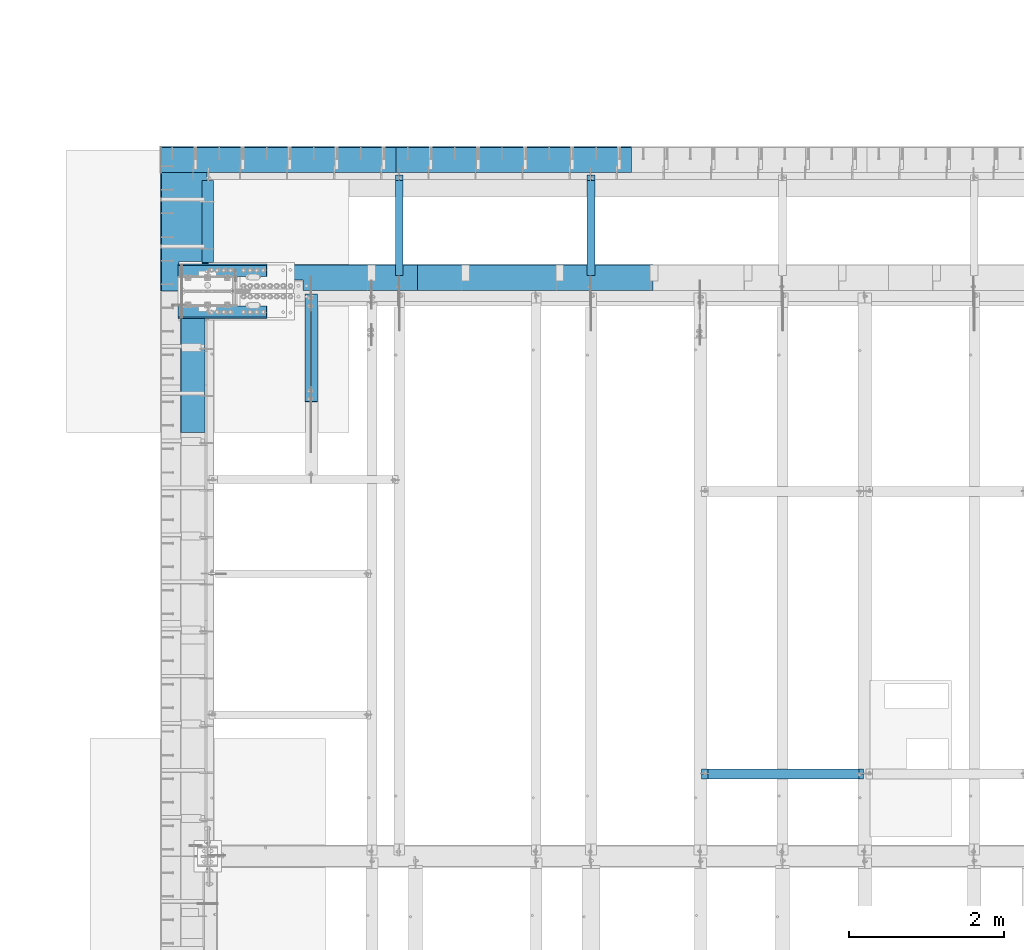
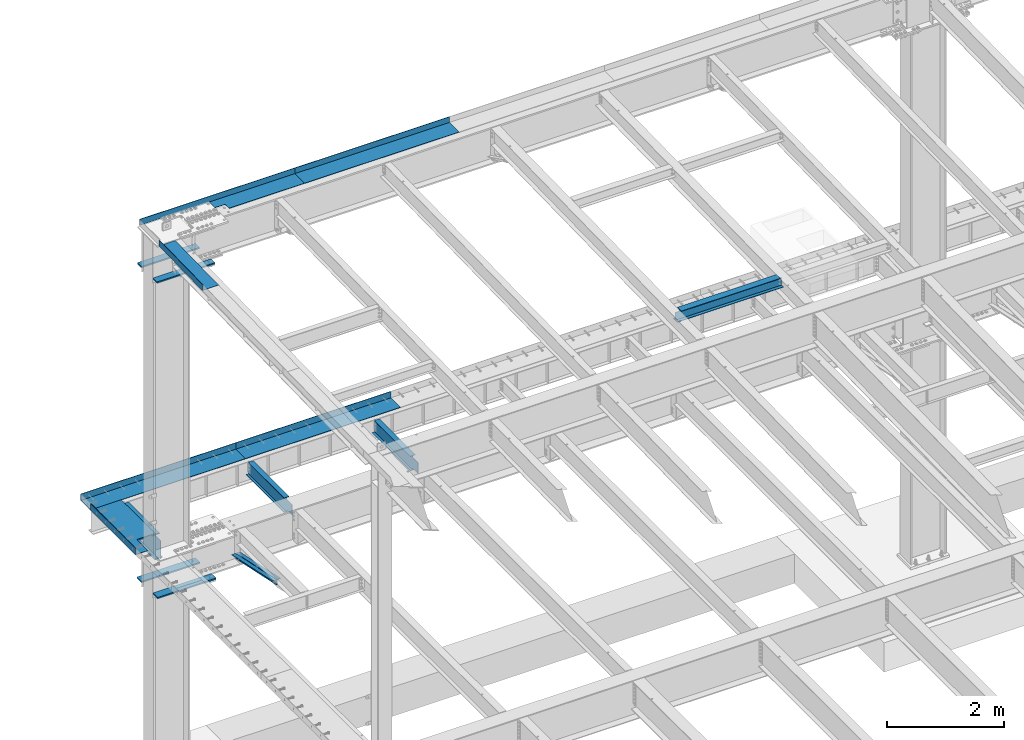
# One storey, part 1125 of 1763: 16 beams, 9 elements without a shape of their own.
"""IFC2X3 building model written with IfcOpenShell, lengths in millimetres."""

from ifc_helpers import new_model, si_unit, frame, origin_with_axes, place, context, subcontext, project, spatial, faceted_brep, material, type_object, element, aggregate, save


model = new_model("IFC2X3")

# Units and contexts
model_context = context("Model", 3, precision=1e-05, world=origin_with_axes())
body_context = subcontext(model_context, "Body", "Model", "MODEL_VIEW")
ifc_project = project(units=[si_unit("LENGTHUNIT", "METRE", prefix="MILLI"), si_unit("AREAUNIT", "SQUARE_METRE"), si_unit("VOLUMEUNIT", "CUBIC_METRE"), si_unit("MASSUNIT", "GRAM", prefix="KILO"), si_unit("TIMEUNIT", "SECOND"), si_unit("PLANEANGLEUNIT", "RADIAN"), si_unit("SOLIDANGLEUNIT", "STERADIAN"), si_unit("THERMODYNAMICTEMPERATUREUNIT", "DEGREE_CELSIUS"), si_unit("LUMINOUSINTENSITYUNIT", "LUMEN")], contexts=[model_context])

# Site, building, storey
site_placement = place(None, origin_with_axes())
site = spatial("IfcSite", under=ifc_project, at=site_placement, CompositionType="ELEMENT")
building_placement = place(site_placement, origin_with_axes())
building = spatial("IfcBuilding", under=site, at=building_placement, Name="Undefined", CompositionType="ELEMENT")
storey_placement = place(building_placement, origin_with_axes())
storey = spatial("IfcBuildingStorey", under=building, at=storey_placement, Name="Undefined", CompositionType="ELEMENT", Elevation=0.0)

# Assembly, beam
assembly_1_placement = place(storey_placement, origin_with_axes())
assembly_1 = element("IfcElementAssembly", 1, at=assembly_1_placement, inside=storey, Name="BEAM", AssemblyPlace="NOTDEFINED", PredefinedType="RIGID_FRAME")
ifc_material_1 = material(Name="STEEL/A992")
beam_type_1 = type_object("IfcBeamType", Name="W8X18", PredefinedType="NOTDEFINED")
beam_1_placement = place(assembly_1_placement, frame((-80902.2926318412, 45872.003125, 11514.3236170495), z_axis=(0.0, 0.0, 1.0), x_axis=(1.0, 0.0, 0.0)))
beam_1 = element("IfcBeam", 2, at=beam_1_placement, type_object=beam_type_1, material=ifc_material_1, Name="BEAM", ObjectType="W8X18", context=body_context, shape_type="Brep", body=[
    faceted_brep([(1960.42688668017, -3.17500000386644, 68.5472454981009), (1960.42688668019, 3.1749999961321, 68.5472454981009), (1959.56590192083, 3.17499999613938, 69.8358002505338), (1959.56590177228, -3.17500000385917, 69.8358004728379), (1964.54706314833, -3.17500000387372, 65.7942315976234), (1964.54706314833, 3.17499999612482, 65.7942315976234), (1969.40714266637, -3.175000003881, 64.8275016750358), (1969.40714266639, 3.17499999611755, 64.8275016750358), (2015.44464294919, -3.17500000397558, 64.8275016750358), (2015.44464276504, 3.17499999602296, 64.8275016750358), (1958.83938981475, -3.17500000385917, 70.3212402430472), (1958.83938963059, 3.17499999613938, 70.3212402430472), (1956.08637573011, 3.17499999613938, 74.4414167112009), (1956.08637591427, -3.17500000385917, 74.4414167112009), (1955.11964580753, 3.17499999614665, 79.3014962292473), (1955.11964599168, -3.17500000385917, 79.3014962292473), (3.17499685616349, 3.17499999998836, 95.25), (3.17499501466227, 66.6749999999884, 95.25), (1955.11964396603, 66.6749999961467, 95.25), (1955.11964580753, 3.17499999614665, 95.25), (3.17499888181919, -66.6750000000102, 103.1875), (3.17499888181919, -66.6750000000102, 95.25), (1955.11964783318, -66.6750000038592, 95.25), (1955.11964783318, -66.6750000038592, 103.1875), (3.17499501466227, 66.6749999999884, 103.1875), (1955.11964396603, 66.6749999961467, 103.1875), (1955.11964599168, -3.17500000385917, 95.25), (3.17499704031798, -3.17500000001019, 95.25), (3.17499685616349, 3.17499999998836, 79.3014961863064), (3.17499704031798, -3.17500000001019, 79.3014961863064), (2.20826693357958, 3.17499999998836, 74.44141666826), (2.20826711773407, -3.17500000001019, 74.44141666826), (-0.544746966901585, 3.17499999999563, 70.3212402001063), (-0.544746782747097, -3.17500000000291, 70.3212402001063), (-1.27125895427889, 3.17499999999563, 69.83580040995), (-1.27125910282484, -3.17500000000291, 69.8358001876459), (-2.13224382305634, 3.17499999999563, 68.5472454937626), (-2.13224382307089, -3.17500000000291, 68.5472454937626), (-6.25242029121728, 3.17500000001019, 65.7942315932851), (-6.25242029121728, -3.17499999998836, 65.7942315932851), (-11.1124998092564, 3.17500000001746, 64.8275016706975), (-11.112499809271, -3.17499999998108, 64.8275016706975), (-79.3750000920845, 3.17500000014843, 64.8275016706975), (-79.37499990793, -3.17499999985012, 64.8275016706975), (-79.3750000920845, 3.17500000014843, -95.25), (-79.3750019335857, 66.6750000001484, -95.25), (-79.3750019335857, 66.6750000001484, -103.1875), (-79.3749980664288, -66.6749999998501, -103.1875), (-79.3749980664288, -66.6749999998501, -95.25), (-79.37499990793, -3.17499999985012, -95.25), (2015.44464276504, 3.17499999602296, -95.25), (2015.44464092355, 66.674999996023, -95.25), (2015.44464092355, 66.674999996023, -103.1875), (2015.4446447907, -66.6750000039756, -103.1875), (2015.4446447907, -66.6750000039756, -95.25), (2015.44464294919, -3.17500000397558, -95.25)], [[[0, 1, 2, 3]], [[4, 5, 1, 0]], [[6, 7, 5, 4]], [[8, 9, 7, 6]], [[10, 11, 12, 13]], [[13, 12, 14, 15]], [[16, 17, 18, 19]], [[20, 21, 22, 23]], [[24, 20, 23, 25]], [[17, 24, 25, 18]], [[23, 22, 26, 15, 14, 19, 18, 25]], [[21, 27, 26, 22]], [[20, 24, 17, 16, 28, 29, 27, 21]], [[29, 28, 30, 31]], [[31, 30, 32, 33]], [[33, 32, 34, 35]], [[35, 34, 36, 37]], [[37, 36, 38, 39]], [[39, 38, 40, 41]], [[41, 40, 42, 43]], [[44, 45, 46, 47, 48, 49, 43, 42]], [[45, 44, 50, 51]], [[46, 45, 51, 52]], [[47, 46, 52, 53]], [[48, 47, 53, 54]], [[49, 48, 54, 55]], [[4, 0, 3, 10, 13, 15, 26, 27, 29, 31, 33, 35, 37, 39, 41, 43, 49, 55, 8, 6]], [[11, 10, 3, 2]], [[50, 44, 42, 40, 38, 36, 34, 32, 30, 28, 16, 19, 14, 12, 11, 2, 1, 5, 7, 9]], [[55, 54, 53, 52, 51, 50, 9, 8]]]),
])
aggregate(assembly_1, [beam_1])

# Assembly, beams
assembly_2_placement = place(storey_placement, origin_with_axes())
assembly_2 = element("IfcElementAssembly", 3, at=assembly_2_placement, inside=storey, Name="COLUMN", AssemblyPlace="NOTDEFINED", PredefinedType="RIGID_FRAME")
ifc_material_2 = material(Name="STEEL/A572-50")
beam_type_2 = type_object("IfcBeamType", PredefinedType="NOTDEFINED")
beam_2_placement = place(assembly_2_placement, frame((-87758.0247736983, 51857.2750002128, 10983.9124917654), z_axis=(0.0, 1.0, 0.0), x_axis=(1.0, 0.0, 0.0)))
beam_2 = element("IfcBeam", 4, at=beam_2_placement, type_object=beam_type_2, material=ifc_material_2, Name="PLATE", context=body_context, shape_type="Brep", body=[
    faceted_brep([(0.0, 14.2875000000004, -69.8499999999985), (0.0, 14.2875000000004, 69.8499999999985), (1143.0, 14.2875000000004, 69.8499999999985), (1143.0, 14.2875000000004, -69.8499999999985), (0.0, -14.2875000000004, 69.8499999999985), (1143.0, -14.2875000000004, 69.8499999999985), (0.0, -14.2875000000004, -69.8499999999985), (1143.0, -14.2875000000004, -69.8499999999985)], [[[0, 1, 2, 3]], [[1, 4, 5, 2]], [[4, 6, 7, 5]], [[6, 0, 3, 7]], [[5, 7, 3, 2]], [[6, 4, 1, 0]]]),
])
beam_3_placement = place(assembly_2_placement, frame((-87758.0247736983, 52384.3250002128, 10983.9124917654), z_axis=(0.0, 1.0, 0.0), x_axis=(1.0, 0.0, 0.0)))
beam_3 = element("IfcBeam", 5, at=beam_3_placement, type_object=beam_type_2, material=ifc_material_2, Name="PLATE", context=body_context, shape_type="Brep", body=[
    faceted_brep([(0.0, 14.2875000000004, -69.8499999999985), (0.0, 14.2875000000004, 69.8499999999985), (1143.0, 14.2875000000004, 69.8499999999985), (1143.0, 14.2875000000004, -69.8499999999985), (0.0, -14.2875000000004, 69.8499999999985), (1143.0, -14.2875000000004, 69.8499999999985), (0.0, -14.2875000000004, -69.8499999999985), (1143.0, -14.2875000000004, -69.8499999999985)], [[[0, 1, 2, 3]], [[1, 4, 5, 2]], [[4, 6, 7, 5]], [[6, 0, 3, 7]], [[5, 7, 3, 2]], [[6, 4, 1, 0]]]),
])
beam_type_3 = type_object("IfcBeamType", PredefinedType="NOTDEFINED")
beam_4_placement = place(assembly_2_placement, frame((-87758.0247736983, 51847.75, 4433.8875), z_axis=(0.0, 1.0, 0.0), x_axis=(1.0, 0.0, 0.0)))
beam_4 = element("IfcBeam", 6, at=beam_4_placement, type_object=beam_type_3, material=ifc_material_2, Name="PLATE", context=body_context, shape_type="Brep", body=[
    faceted_brep([(0.0, 14.2875000000004, -79.375), (0.0, 14.2875000000004, 79.375), (1152.52499999999, 14.2875000000004, 79.375), (1152.52499999999, 14.2875000000004, -79.375), (0.0, -14.2875000000004, 79.375), (1152.52499999999, -14.2875000000004, 79.375), (0.0, -14.2875000000004, -79.375), (1152.52499999999, -14.2875000000004, -79.375)], [[[0, 1, 2, 3]], [[1, 4, 5, 2]], [[4, 6, 7, 5]], [[6, 0, 3, 7]], [[5, 7, 3, 2]], [[6, 4, 1, 0]]]),
])
beam_5_placement = place(assembly_2_placement, frame((-87758.0247736983, 52393.85, 4433.8875), z_axis=(0.0, 1.0, 0.0), x_axis=(1.0, 0.0, 0.0)))
beam_5 = element("IfcBeam", 7, at=beam_5_placement, type_object=beam_type_3, material=ifc_material_2, Name="PLATE", context=body_context, shape_type="Brep", body=[
    faceted_brep([(0.0, 14.2875000000004, -79.375), (0.0, 14.2875000000004, 79.375), (1152.52499999999, 14.2875000000004, 79.375), (1152.52499999999, 14.2875000000004, -79.375), (0.0, -14.2875000000004, 79.375), (1152.52499999999, -14.2875000000004, 79.375), (0.0, -14.2875000000004, -79.375), (1152.52499999999, -14.2875000000004, -79.375)], [[[0, 1, 2, 3]], [[1, 4, 5, 2]], [[4, 6, 7, 5]], [[6, 0, 3, 7]], [[5, 7, 3, 2]], [[6, 4, 1, 0]]]),
])
aggregate(assembly_2, [beam_2, beam_3, beam_4, beam_5])

assembly_3_placement = place(storey_placement, origin_with_axes())
assembly_3 = element("IfcElementAssembly", 8, at=assembly_3_placement, inside=storey, Name="ANGLE BRACE", AssemblyPlace="NOTDEFINED", PredefinedType="RIGID_FRAME")
ifc_material_3 = material(Name="STEEL/A36")
beam_type_4 = type_object("IfcBeamType", Name="L4X3X5/16", PredefinedType="NOTDEFINED")
beam_6_placement = place(assembly_3_placement, frame((-86080.0372736984, 50680.4564530846, 4820.75267554856), z_axis=(0.0, -0.2072236520035, -0.978293595016513), x_axis=(0.0, 0.978293600950479, -0.20722362398951)))
beam_6 = element("IfcBeam", 9, at=beam_6_placement, type_object=beam_type_4, material=ifc_material_3, Name="ANGLE BRACE", ObjectType="L4X3X5/16", context=body_context, shape_type="Brep", body=[
    faceted_brep([(1.45519152283669e-10, 38.0999999999985, -50.7999999999993), (1.45519152283669e-10, 38.0999999999985, 50.7999999999993), (1427.42255777739, 38.0999999999985, 50.7999999995518), (1427.42255777754, 38.0999999999985, -50.8000000004868), (-7.27595761418343e-11, 30.1624999999985, 50.8000000000211), (1427.42255777739, 30.1624999999985, 50.7999999995518), (7.27595761418343e-11, 30.1624999999985, -42.8625000000175), (1427.42255777754, 30.1624999999985, -42.8625000004868), (7.27595761418343e-11, -38.0999999999985, -42.8625000000175), (1427.42255777754, -38.0999999999985, -42.8625000004868), (-1.23691279441118e-10, -38.1000000000022, -50.7999999999993), (1427.42255777754, -38.0999999999985, -50.8000000004868)], [[[0, 1, 2, 3]], [[1, 4, 5, 2]], [[4, 6, 7, 5]], [[6, 8, 9, 7]], [[8, 10, 11, 9]], [[10, 0, 3, 11]], [[5, 7, 9, 11, 3, 2]], [[10, 8, 6, 4, 1, 0]]]),
])
beam_7_placement = place(assembly_3_placement, frame((-85994.3122736983, 52076.9355387112, 4524.94833056974), z_axis=(0.0, -0.2072236520035, -0.978293595016513), x_axis=(0.0, -0.978293595016513, 0.207223652003498)))
beam_7 = element("IfcBeam", 10, at=beam_7_placement, type_object=beam_type_4, material=ifc_material_3, Name="ANGLE BRACE", ObjectType="L4X3X5/16", context=body_context, shape_type="Brep", body=[
    faceted_brep([(1.45519152283669e-10, 38.0999999999985, -50.7999999999993), (1.45519152283669e-10, 38.0999999999985, 50.7999999999993), (1427.46422513096, 38.0999999999985, 50.7999999991189), (1427.46422513096, 38.0999999999985, -50.8000000008396), (-7.27595761418343e-11, 30.1624999999985, 50.8000000000211), (1427.46422513096, 30.1624999999985, 50.7999999991189), (7.27595761418343e-11, 30.1624999999985, -42.8625000000175), (1427.46422513096, 30.1624999999985, -42.8625000008433), (7.27595761418343e-11, -38.0999999999985, -42.8625000000175), (1427.46422513096, -38.0999999999985, -42.8625000008433), (-1.23691279441118e-10, -38.1000000000022, -50.7999999999993), (1427.46422513096, -38.0999999999985, -50.8000000008396)], [[[0, 1, 2, 3]], [[1, 4, 5, 2]], [[4, 6, 7, 5]], [[6, 8, 9, 7]], [[8, 10, 11, 9]], [[10, 0, 3, 11]], [[5, 7, 9, 11, 3, 2]], [[10, 8, 6, 4, 1, 0]]]),
])
aggregate(assembly_3, [beam_6, beam_7])

# Assembly, beam
assembly_4_placement = place(storey_placement, origin_with_axes())
assembly_4 = element("IfcElementAssembly", 11, at=assembly_4_placement, inside=storey, Name="BEAM", AssemblyPlace="NOTDEFINED", PredefinedType="RIGID_FRAME")
beam_type_5 = type_object("IfcBeamType", PredefinedType="NOTDEFINED")
beam_8_placement = place(assembly_4_placement, frame((-87381.7872736983, 52890.7375, 5199.0625), z_axis=(0.0, -1.0, 0.0), x_axis=(-1.0, 0.0, 0.0)))
beam_8 = element("IfcBeam", 12, at=beam_8_placement, type_object=beam_type_5, material=ifc_material_3, Name="BENT_PLATE", context=body_context, shape_type="Brep", body=[
    faceted_brep([(363.537500000006, -4.76249999999982, 385.762499999997), (363.537500000006, 4.76249999999982, 385.762499999997), (0.0, 4.76249999999982, 385.762499999997), (0.0, -4.76249999999982, 385.762499999997), (363.537500000006, -4.76249999999982, 766.762499999983), (363.537500000006, 4.76249999999982, 766.762499999997), (593.725000000006, -4.76249999999982, -766.762499999997), (0.0, -4.76249999999982, -766.762499999997), (0.0, 4.76249999999982, -766.762499999997), (603.25, 4.76249999999982, -766.762499999997), (603.25, -134.937496948242, -766.762499999997), (593.725000000006, -134.937496948242, -766.762499999997), (603.25, 4.76249999999982, 766.762499999997), (603.25, -134.937496948242, 766.762499999997), (593.725000000006, -134.937496948242, 766.762499999997), (593.725000000006, -4.76249999999982, 766.762499999997)], [[[0, 1, 2, 3]], [[4, 5, 1, 0]], [[6, 7, 8, 9, 10, 11]], [[9, 12, 13, 10]], [[14, 11, 10, 13]], [[15, 6, 11, 14]], [[3, 7, 6, 15, 4, 0]], [[8, 7, 3, 2]], [[12, 9, 8, 2, 1, 5]], [[15, 14, 13, 12, 5, 4]]]),
])

# Assembly, beams
assembly_5_placement = place(storey_placement, origin_with_axes())
assembly_5 = element("IfcElementAssembly", 13, at=assembly_5_placement, inside=storey, Name="BEAM", AssemblyPlace="NOTDEFINED", PredefinedType="RIGID_FRAME")
beam_type_6 = type_object("IfcBeamType", PredefinedType="NOTDEFINED")
beam_9_placement = place(assembly_5_placement, frame((-83135.2247736984, 52133.5000002128, 11752.2624917654), z_axis=(-1.0, 0.0, 0.0), x_axis=(0.0, 1.0, 0.0)))
beam_9 = element("IfcBeam", 14, at=beam_9_placement, type_object=beam_type_6, material=ifc_material_3, Name="BENT_PLATE", context=body_context, shape_type="Brep", body=[
    faceted_brep([(0.0, -4.76249999999982, -1524.0), (0.0, -4.76249999999982, 1524.0), (0.0, 4.76249999999982, 1524.0), (0.0, 4.76249999999982, -1524.0), (336.549987792969, 4.76250000000073, 1524.0), (336.549987792969, 4.76250000000073, -1524.0), (327.024987792975, -4.76250000000073, -1524.0), (327.024987792967, -4.76250000000073, 1524.00000000001), (336.549987792969, -122.237499999999, 1524.0), (336.549987792969, -122.237499999999, -1524.0), (327.024987792975, -122.237499999999, 1524.0), (327.024987792975, -122.237499999999, -1524.0)], [[[0, 1, 2, 3]], [[3, 2, 4, 5]], [[1, 0, 6, 7]], [[5, 4, 8, 9]], [[4, 2, 1, 7, 10, 8]], [[7, 6, 11, 10]], [[6, 0, 3, 5, 9, 11]], [[10, 11, 9, 8]]]),
])
beam_type_7 = type_object("IfcBeamType", PredefinedType="NOTDEFINED")
beam_10_placement = place(assembly_5_placement, frame((-86183.2247736984, 52133.5000002128, 11752.2624917654), z_axis=(-1.0, 0.0, 0.0), x_axis=(0.0, 1.0, 0.0)))
beam_10 = element("IfcBeam", 15, at=beam_10_placement, type_object=beam_type_7, material=ifc_material_3, Name="BENT_PLATE", context=body_context, shape_type="Brep", body=[
    faceted_brep([(133.35001525878, -4.76250000000073, -44.4498535156163), (133.35001525878, 4.76250000000073, -44.4498535156163), (0.0, 4.76250000000073, -44.4498535156163), (0.0, -4.76250000000073, -44.4498535156163), (133.35001525878, -4.76250000000073, 158.750097656259), (133.35001525878, 4.76250000000073, 158.750097656259), (327.024987792975, -4.76250000000073, 158.750097656259), (327.024987793302, 4.76250000000073, 158.750097656259), (327.024987792967, -4.76250000000073, 1524.00000000001), (327.024987792967, 4.76250000000073, 1524.0), (327.024987792975, -4.76250000000073, -1524.0), (0.0, -4.76249999999982, -1524.0), (0.0, 4.76249999999982, -1524.0), (336.549987792969, 4.76250000000073, -1524.0), (336.549987792969, -122.237499999999, -1524.0), (327.024987792975, -122.237499999999, -1524.0), (336.549987792969, 4.76250000000073, 1524.0), (336.549987792969, -122.237499999999, 1524.0), (327.024987792975, -122.237499999999, 1524.0), (327.024987792975, -99.5375007629373, 1524.0)], [[[0, 1, 2, 3]], [[4, 5, 1, 0]], [[6, 7, 5, 4]], [[8, 9, 7, 6]], [[10, 11, 12, 13, 14, 15]], [[13, 16, 17, 14]], [[18, 15, 14, 17]], [[19, 8, 6, 10, 15, 18]], [[0, 3, 11, 10, 6, 4]], [[12, 11, 3, 2]], [[16, 13, 12, 2, 1, 5, 7, 9]], [[19, 18, 17, 16, 9, 8]]]),
])
aggregate(assembly_5, [beam_10, beam_9])

# Assembly, beam
assembly_6_placement = place(storey_placement, origin_with_axes())
assembly_6 = element("IfcElementAssembly", 16, at=assembly_6_placement, inside=storey, Name="BEAM", AssemblyPlace="NOTDEFINED", PredefinedType="RIGID_FRAME")
beam_type_8 = type_object("IfcBeamType", PredefinedType="NOTDEFINED")
beam_11_placement = place(assembly_6_placement, frame((-87407.1872736983, 51034.067612332, 11728.1915532733), z_axis=(0.0, -0.999786037781472, -0.0206852279954809), x_axis=(-1.0, 0.0, 0.0)))
beam_11 = element("IfcBeam", 17, at=beam_11_placement, type_object=beam_type_8, material=ifc_material_3, Name="BENT_PLATE", context=body_context, shape_type="Brep", body=[
    faceted_brep([(0.0, -3.174999999801, -740.118000002141), (-1.45519152283669e-11, -3.17500000019572, 740.118000002127), (0.0, 3.17499999979918, 740.118000002134), (1.45519152283669e-11, 3.17500000019027, -740.118000002134), (317.500000000087, 3.17499999899519, 740.118000002127), (317.500000000146, 3.17499999938627, -740.118000002134), (311.15000000014, -3.17500000059226, -740.118000002134), (311.150000000081, -3.17500000098516, 740.118000002127), (317.500000000116, -123.824997298514, 740.118000002112), (317.500000000116, -123.824997298163, -740.118000002156), (311.150000000111, -123.824997298514, 740.118000002112), (311.150000000111, -123.824997298163, -740.118000002156)], [[[0, 1, 2, 3]], [[3, 2, 4, 5]], [[1, 0, 6, 7]], [[5, 4, 8, 9]], [[4, 2, 1, 7, 10, 8]], [[7, 6, 11, 10]], [[6, 0, 3, 5, 9, 11]], [[10, 11, 9, 8]]]),
])
aggregate(assembly_6, [beam_11])

# Assembly, beams
assembly_7_placement = place(storey_placement, origin_with_axes())
assembly_7 = element("IfcElementAssembly", 18, at=assembly_7_placement, inside=storey, Name="BEAM", AssemblyPlace="NOTDEFINED", PredefinedType="RIGID_FRAME")
beam_type_9 = type_object("IfcBeamType", PredefinedType="NOTDEFINED")
beam_12_placement = place(assembly_7_placement, frame((-83413.0372736984, 53657.5, 5199.0625), z_axis=(1.0, 0.0, 0.0), x_axis=(0.0, 1.0, 0.0)))
beam_12 = element("IfcBeam", 19, at=beam_12_placement, type_object=beam_type_9, material=ifc_material_3, Name="BENT PLATE", context=body_context, shape_type="Brep", body=[
    faceted_brep([(0.0, -4.76249999999982, -1524.0), (0.0, -4.76249999999982, 1524.0), (0.0, 4.76249999999982, 1524.0), (0.0, 4.76249999999982, -1524.0), (327.024987792967, 4.76250000000073, 1524.0), (327.025018310553, 4.76249999999982, -1524.0), (336.550018310547, -4.76249999999982, -1524.0), (336.550018310547, -4.76249999999982, 1524.0), (327.025018310553, 134.937496948242, 1524.0), (327.025018310553, 134.937496948242, -1524.0), (336.550018310547, 134.937496948242, 1524.0), (336.550018310547, 134.937496948242, -1524.0)], [[[0, 1, 2, 3]], [[3, 2, 4, 5]], [[1, 0, 6, 7]], [[5, 4, 8, 9]], [[4, 2, 1, 7, 10, 8]], [[7, 6, 11, 10]], [[6, 0, 3, 5, 9, 11]], [[10, 11, 9, 8]]]),
])
beam_13_placement = place(assembly_7_placement, frame((-86461.0372736984, 53657.5, 5199.0625), z_axis=(1.0, 0.0, 0.0), x_axis=(0.0, 1.0, 0.0)))
beam_13 = element("IfcBeam", 20, at=beam_13_placement, type_object=beam_type_9, material=ifc_material_3, Name="BENT PLATE", context=body_context, shape_type="Brep", body=[
    faceted_brep([(0.0, -4.76249999999982, -1524.0), (0.0, -4.76249999999982, 1524.0), (0.0, 4.76249999999982, 1524.0), (0.0, 4.76249999999982, -1524.0), (327.024987792967, 4.76250000000073, 1524.0), (327.025018310553, 4.76249999999982, -1524.0), (336.550018310547, -4.76249999999982, -1524.0), (336.550018310547, -4.76249999999982, 1524.0), (327.025018310553, 134.937496948242, 1524.0), (327.025018310553, 134.937496948242, -1524.0), (336.550018310547, 134.937496948242, 1524.0), (336.550018310547, 134.937496948242, -1524.0)], [[[0, 1, 2, 3]], [[3, 2, 4, 5]], [[1, 0, 6, 7]], [[5, 4, 8, 9]], [[4, 2, 1, 7, 10, 8]], [[7, 6, 11, 10]], [[6, 0, 3, 5, 9, 11]], [[10, 11, 9, 8]]]),
])
aggregate(assembly_7, [beam_12, beam_13])

# Assembly, beam
assembly_8_placement = place(storey_placement, origin_with_axes())
assembly_8 = element("IfcElementAssembly", 21, at=assembly_8_placement, inside=storey, Name="BEAM", AssemblyPlace="NOTDEFINED", PredefinedType="RIGID_FRAME")
beam_type_10 = type_object("IfcBeamType", Name="W12X16", PredefinedType="NOTDEFINED")
beam_14_placement = place(assembly_8_placement, frame((-82413.9706070317, 52120.8, 5041.9), z_axis=(0.0, 0.0, 1.0), x_axis=(0.0, 1.0, 0.0)))
beam_14 = element("IfcBeam", 22, at=beam_14_placement, type_object=beam_type_10, material=ifc_material_1, Name="BEAM", ObjectType="W12X16", context=body_context, shape_type="Brep", body=[
    faceted_brep([(20.6374999999971, -3.17500000000291, -114.3), (20.6374999999971, 3.17500000000291, -114.3), (192.087500190733, 3.17500000000291, -114.3), (192.087500190733, -3.17500000000291, -114.3), (196.94757970878, 3.17500000000291, -115.266729922588), (196.94757970878, -3.17500000000291, -115.266729922588), (201.067756176933, 3.17500000000291, -118.019743823066), (201.067756176933, -3.17500000000291, -118.019743823066), (203.820770077407, 3.17500000000291, -122.13992029122), (203.820770077407, -3.17500000000291, -122.13992029122), (204.787499999999, -3.17500000000291, -126.999999809265), (204.787499999999, 3.17500000000291, -126.999999809265), (204.787499999999, 3.17500000000291, -146.05), (204.787499999999, 50.8000000000029, -146.05), (204.787499999999, 50.8000000000029, -152.4), (204.787499999999, -50.8000000000029, -152.4), (204.787499999999, -50.8000000000029, -146.05), (204.787499999999, -3.17500000000291, -146.05), (1431.13125000001, 50.8000000000029, 146.05), (1431.13125000001, 3.17500000000291, 146.05), (204.787499999999, 3.17500000000291, 146.05), (204.787499999999, 50.8000000000029, 146.05), (192.087500190733, -3.17500000000291, 114.3), (192.087500190733, 3.17500000000291, 114.3), (20.6374999999971, 3.17500000000291, 114.3), (20.6374999999971, -3.17500000000291, 114.3), (196.94757970878, -3.17500000000291, 115.266729922588), (196.94757970878, 3.17500000000291, 115.266729922588), (201.067756176933, -3.17500000000291, 118.019743823066), (201.067756176933, 3.17500000000291, 118.019743823066), (203.820770077407, -3.17500000000291, 122.13992029122), (203.820770077407, 3.17500000000291, 122.13992029122), (204.787499999999, -3.17500000000291, 126.999999809265), (204.787499999999, 3.17500000000291, 126.999999809265), (1431.13125000001, -50.8000000000029, 152.4), (1431.13125000001, 50.8000000000029, 152.4), (204.787499999999, 50.8000000000029, 152.4), (204.787499999999, -50.8000000000029, 152.4), (1431.13125000001, -50.8000000000029, 146.05), (204.787499999999, -50.8000000000029, 146.05), (1431.13125000001, -3.17500000000291, 146.05), (204.787499999999, -3.17500000000291, 146.05), (1431.13125000001, -3.17500000000291, 139.440001487732), (1431.13125000001, 3.17500000000291, 139.440001487732), (1432.0979799226, -3.17500000000291, 134.579921969686), (1432.0979799226, 3.17500000000291, 134.579921969686), (1434.85099382307, -3.17500000000291, 130.459745501533), (1434.85099382307, 3.17500000000291, 130.459745501533), (1438.97117029122, -3.17500000000291, 127.706731601054), (1438.97117029122, 3.17500000000291, 127.706731601054), (1443.83124980927, -3.17500000000291, 126.740001678467), (1443.83124980927, 3.17500000000291, 126.740001678467), (1507.33125, -3.17500000000291, 126.740001678467), (1507.33125, 3.17500000000291, 126.740001678467), (1507.33125, -3.17500000000291, -146.05), (1507.33125, -50.8000000000029, -146.05), (1507.33125, -50.8000000000029, -152.4), (1507.33125, 50.8000000000029, -152.4), (1507.33125, 50.8000000000029, -146.05), (1507.33125, 3.17500000000291, -146.05)], [[[0, 1, 2, 3]], [[3, 2, 4, 5]], [[5, 4, 6, 7]], [[7, 6, 8, 9]], [[10, 11, 12, 13, 14, 15, 16, 17]], [[9, 8, 11, 10]], [[18, 19, 20, 21]], [[22, 23, 24, 25]], [[26, 27, 23, 22]], [[28, 29, 27, 26]], [[30, 31, 29, 28]], [[32, 33, 31, 30]], [[34, 35, 36, 37]], [[38, 34, 37, 39]], [[40, 38, 39, 41]], [[37, 36, 21, 20, 33, 32, 41, 39]], [[35, 18, 21, 36]], [[34, 38, 40, 42, 43, 19, 18, 35]], [[44, 45, 43, 42]], [[46, 47, 45, 44]], [[48, 49, 47, 46]], [[50, 51, 49, 48]], [[52, 53, 51, 50]], [[54, 55, 56, 57, 58, 59, 53, 52]], [[55, 54, 17, 16]], [[56, 55, 16, 15]], [[57, 56, 15, 14]], [[58, 57, 14, 13]], [[59, 58, 13, 12]], [[6, 4, 2, 1, 24, 23, 27, 29, 31, 33, 20, 19, 43, 45, 47, 49, 51, 53, 59, 12, 11, 8]], [[25, 24, 1, 0]], [[54, 52, 50, 48, 46, 44, 42, 40, 41, 32, 30, 28, 26, 22, 25, 0, 3, 5, 7, 9, 10, 17]]]),
])
aggregate(assembly_8, [beam_14])

assembly_9_placement = place(storey_placement, origin_with_axes())
assembly_9 = element("IfcElementAssembly", 23, at=assembly_9_placement, inside=storey, Name="BEAM", AssemblyPlace="NOTDEFINED", PredefinedType="RIGID_FRAME")
beam_15_placement = place(assembly_9_placement, frame((-84894.703940365, 52120.8, 5041.9), z_axis=(0.0, 0.0, 1.0), x_axis=(0.0, 1.0, 0.0)))
beam_15 = element("IfcBeam", 24, at=beam_15_placement, type_object=beam_type_10, material=ifc_material_1, Name="BEAM", ObjectType="W12X16", context=body_context, shape_type="Brep", body=[
    faceted_brep([(20.6374999999971, -3.17500000000291, -114.3), (20.6374999999971, 3.17500000000291, -114.3), (192.087500190733, 3.17500000000291, -114.3), (192.087500190733, -3.17500000000291, -114.3), (196.94757970878, 3.17500000000291, -115.266729922588), (196.94757970878, -3.17500000000291, -115.266729922588), (201.067756176933, 3.17500000000291, -118.019743823066), (201.067756176933, -3.17500000000291, -118.019743823066), (203.820770077407, 3.17500000000291, -122.13992029122), (203.820770077407, -3.17500000000291, -122.13992029122), (204.787499999999, -3.17500000000291, -126.999999809265), (204.787499999999, 3.17500000000291, -126.999999809265), (204.787499999999, 3.17500000000291, -146.05), (204.787499999999, 50.8000000000029, -146.05), (204.787499999999, 50.8000000000029, -152.4), (204.787499999999, -50.8000000000029, -152.4), (204.787499999999, -50.8000000000029, -146.05), (204.787499999999, -3.17500000000291, -146.05), (1431.13125000001, 50.8000000000029, 146.05), (1431.13125000001, 3.17500000000291, 146.05), (204.787499999999, 3.17500000000291, 146.05), (204.787499999999, 50.8000000000029, 146.05), (192.087500190733, -3.17500000000291, 114.3), (192.087500190733, 3.17500000000291, 114.3), (20.6374999999971, 3.17500000000291, 114.3), (20.6374999999971, -3.17500000000291, 114.3), (196.94757970878, -3.17500000000291, 115.266729922588), (196.94757970878, 3.17500000000291, 115.266729922588), (201.067756176933, -3.17500000000291, 118.019743823066), (201.067756176933, 3.17500000000291, 118.019743823066), (203.820770077407, -3.17500000000291, 122.13992029122), (203.820770077407, 3.17500000000291, 122.13992029122), (204.787499999999, -3.17500000000291, 126.999999809265), (204.787499999999, 3.17500000000291, 126.999999809265), (1431.13125000001, -50.8000000000029, 152.4), (1431.13125000001, 50.8000000000029, 152.4), (204.787499999999, 50.8000000000029, 152.4), (204.787499999999, -50.8000000000029, 152.4), (1431.13125000001, -50.8000000000029, 146.05), (204.787499999999, -50.8000000000029, 146.05), (1431.13125000001, -3.17500000000291, 146.05), (204.787499999999, -3.17500000000291, 146.05), (1431.13125000001, -3.17500000000291, 139.440001487732), (1431.13125000001, 3.17500000000291, 139.440001487732), (1432.0979799226, -3.17500000000291, 134.579921969686), (1432.0979799226, 3.17500000000291, 134.579921969686), (1434.85099382307, -3.17500000000291, 130.459745501533), (1434.85099382307, 3.17500000000291, 130.459745501533), (1438.97117029122, -3.17500000000291, 127.706731601054), (1438.97117029122, 3.17500000000291, 127.706731601054), (1443.83124980927, -3.17500000000291, 126.740001678467), (1443.83124980927, 3.17500000000291, 126.740001678467), (1507.33125, -3.17500000000291, 126.740001678467), (1507.33125, 3.17500000000291, 126.740001678467), (1507.33125, -3.17500000000291, -146.05), (1507.33125, -50.8000000000029, -146.05), (1507.33125, -50.8000000000029, -152.4), (1507.33125, 50.8000000000029, -152.4), (1507.33125, 50.8000000000029, -146.05), (1507.33125, 3.17500000000291, -146.05)], [[[0, 1, 2, 3]], [[3, 2, 4, 5]], [[5, 4, 6, 7]], [[7, 6, 8, 9]], [[10, 11, 12, 13, 14, 15, 16, 17]], [[9, 8, 11, 10]], [[18, 19, 20, 21]], [[22, 23, 24, 25]], [[26, 27, 23, 22]], [[28, 29, 27, 26]], [[30, 31, 29, 28]], [[32, 33, 31, 30]], [[34, 35, 36, 37]], [[38, 34, 37, 39]], [[40, 38, 39, 41]], [[37, 36, 21, 20, 33, 32, 41, 39]], [[35, 18, 21, 36]], [[34, 38, 40, 42, 43, 19, 18, 35]], [[44, 45, 43, 42]], [[46, 47, 45, 44]], [[48, 49, 47, 46]], [[50, 51, 49, 48]], [[52, 53, 51, 50]], [[54, 55, 56, 57, 58, 59, 53, 52]], [[55, 54, 17, 16]], [[56, 55, 16, 15]], [[57, 56, 15, 14]], [[58, 57, 14, 13]], [[59, 58, 13, 12]], [[6, 4, 2, 1, 24, 23, 27, 29, 31, 33, 20, 19, 43, 45, 47, 49, 51, 53, 59, 12, 11, 8]], [[25, 24, 1, 0]], [[54, 52, 50, 48, 46, 44, 42, 40, 41, 32, 30, 28, 26, 22, 25, 0, 3, 5, 7, 9, 10, 17]]]),
])
aggregate(assembly_9, [beam_15])

# Beam
beam_type_11 = type_object("IfcBeamType", Name="W18X40", PredefinedType="NOTDEFINED")
beam_16_placement = place(assembly_4_placement, frame((-87375.4372736983, 52120.8, 4967.2875), z_axis=(0.0, 0.0, 1.0), x_axis=(0.0, 1.0, 0.0)))
beam_16 = element("IfcBeam", 25, at=beam_16_placement, type_object=beam_type_11, material=ifc_material_1, Name="BEAM", ObjectType="W18X40", context=body_context, shape_type="Brep", body=[
    faceted_brep([(369.282576987374, -76.1999999999971, 227.0125), (369.282576987374, 76.1999999999971, 227.0125), (361.950015724411, 76.1999999999971, 214.3125), (361.950015724411, 3.96875, 214.3125), (361.720800503084, 3.96875, 213.91549911499), (361.720800503084, -3.96875, 213.91549911499), (361.950015724411, -3.96875, 214.3125), (361.950015724411, -76.1999999999971, 214.3125), (387.350000000006, -3.96875, 213.91549911499), (387.350000000006, 3.96875, 213.91549911499), (408.559104070635, 3.96875, 204.211830867132), (408.559104070635, -3.96875, 204.211830867132), (411.597019765919, 3.96875, 201.276913128712), (411.597019765919, -3.96875, 201.276913128712), (412.121624418498, 3.96875, 197.085557278698), (412.121624418498, -3.96875, 197.085557278698), (409.900780883465, 3.96875, 193.492434974088), (409.900780883465, -3.96875, 193.492434974088), (405.917210673026, 3.96875, 192.0875), (405.917210673026, -3.96875, 192.0875), (206.375, 3.96875, 192.0875), (206.375, -3.96875, 192.0875), (206.375, 3.96875, -192.0875), (206.375, -3.96875, -192.0875), (296.233211039238, 3.96875, -192.0875), (296.233211039238, -3.96875, -192.0875), (300.216781249677, 3.96875, -193.492434974089), (300.216781249677, -3.96875, -193.492434974089), (302.43762478471, 3.96875, -197.085557278698), (302.43762478471, -3.96875, -197.085557278698), (301.913020132131, 3.96875, -201.276913128712), (301.913020132131, -3.96875, -201.276913128712), (298.875104436847, 3.96875, -204.211830867132), (298.875104436847, -3.96875, -204.211830867132), (277.666000366218, 3.96875, -213.91549911499), (277.666000366218, -3.96875, -213.91549911499), (1431.13125, 76.1999999999971, -214.3125), (1431.13125, 76.1999999999971, -227.0125), (269.875407506574, 76.1999999999971, -227.0125), (277.207595789965, 76.1999999999971, -214.3125), (1431.13125, -76.1999999999971, -227.0125), (269.875407506574, -76.1999999999971, -227.0125), (1431.13125, -76.1999999999971, -214.3125), (277.207595789965, -76.1999999999971, -214.3125), (1431.13125, -3.96875, -214.3125), (277.207595789965, -3.96875, -214.3125), (277.207595789965, 3.96875, -214.3125), (1431.13125, 3.96875, -214.3125), (1432.09797992259, 3.96875, -209.45242029122), (1432.09797992259, -3.96875, -209.45242029122), (1434.85099382306, 3.96875, -205.332243823066), (1434.85099382306, -3.96875, -205.332243823066), (1438.97117029122, 3.96875, -202.579229922588), (1438.97117029122, -3.96875, -202.579229922588), (1443.83124980926, 3.96875, -201.6125), (1443.83124980926, -3.96875, -201.6125), (1507.33124999999, -3.96875, -201.6125), (1507.33124999999, 3.96875, -201.6125), (1507.33124999999, 3.96875, 201.6125), (1507.33124999999, -3.96875, 201.6125), (1443.83124980926, 3.96875, 201.6125), (1443.83124980926, -3.96875, 201.6125), (1438.97117029122, 3.96875, 202.579229922588), (1438.97117029122, -3.96875, 202.579229922588), (1434.85099382306, 3.96875, 205.332243823066), (1434.85099382306, -3.96875, 205.332243823066), (1432.09797992259, 3.96875, 209.45242029122), (1432.09797992259, -3.96875, 209.45242029122), (1431.13125, 3.96875, 214.3125), (1431.13125, -3.96875, 214.3125), (1431.13125, -76.1999999999971, 227.0125), (1431.13125, -76.1999999999971, 214.3125), (1431.13125, 76.1999999999971, 214.3125), (1431.13125, 76.1999999999971, 227.0125)], [[[0, 1, 2, 3, 4, 5, 6, 7]], [[8, 9, 10, 11]], [[11, 10, 12, 13]], [[13, 12, 14, 15]], [[15, 14, 16, 17]], [[17, 16, 18, 19]], [[19, 18, 20, 21]], [[22, 23, 21, 20]], [[23, 22, 24, 25]], [[25, 24, 26, 27]], [[27, 26, 28, 29]], [[29, 28, 30, 31]], [[31, 30, 32, 33]], [[33, 32, 34, 35]], [[36, 37, 38, 39]], [[37, 40, 41, 38]], [[40, 42, 43, 41]], [[42, 44, 45, 43]], [[35, 34, 46, 39, 38, 41, 43, 45]], [[47, 36, 39, 46]], [[42, 40, 37, 36, 47, 44]], [[44, 47, 48, 49]], [[49, 48, 50, 51]], [[51, 50, 52, 53]], [[53, 52, 54, 55]], [[56, 55, 54, 57]], [[58, 59, 56, 57]], [[59, 58, 60, 61]], [[61, 60, 62, 63]], [[63, 62, 64, 65]], [[65, 64, 66, 67]], [[67, 66, 68, 69]], [[70, 71, 69, 68, 72, 73]], [[71, 70, 0, 7]], [[69, 71, 7, 6]], [[8, 11, 13, 15, 17, 19, 21, 23, 25, 27, 29, 31, 33, 35, 45, 44, 49, 51, 53, 55, 56, 59, 61, 63, 65, 67, 69, 6, 5]], [[9, 8, 5, 4]], [[68, 66, 64, 62, 60, 58, 57, 54, 52, 50, 48, 47, 46, 34, 32, 30, 28, 26, 24, 22, 20, 18, 16, 14, 12, 10, 9, 4, 3]], [[72, 68, 3, 2]], [[73, 72, 2, 1]], [[70, 73, 1, 0]]]),
])

aggregate(assembly_4, [beam_8, beam_16])

save(model, "model.ifc")
